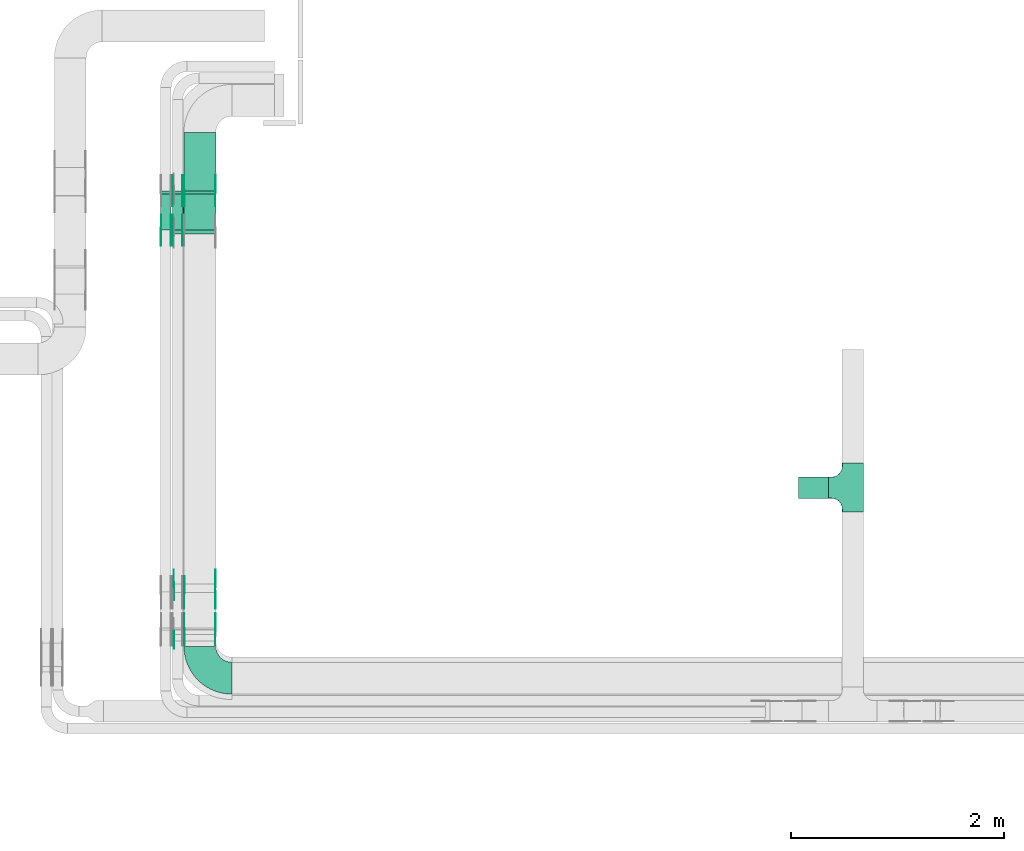
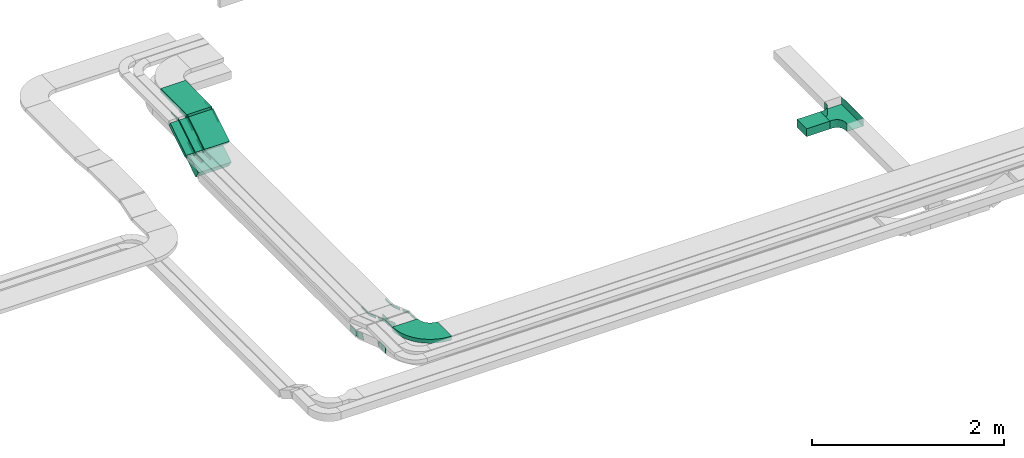
# One storey, part 8 of 28: 31 flow fittings, 6 flow segments.
"""IFC2X3 building model written with IfcOpenShell, lengths in millimetres."""

from ifc_helpers import new_model, entity, si_unit, converted_unit, derived_unit, direction, frame, frame_2d, origin, origin_2d_with_axis, place, context, subcontext, project, spatial, polyline, circle_curve, parameter, trimmed, segment, composite_curve, rectangle, outline, extrude, faceted_brep, source, transform, mapped, material, type_object, type_shapes, element, save


model = new_model("IFC2X3")

# Units and contexts
model_context = context("Model", 3, precision=0.01, world=origin(), true_north=direction((6.12303176911189e-17, 1.0)))
body_context = subcontext(model_context, "Body", "Model", "MODEL_VIEW")
ifc_project = project(units=[si_unit("LENGTHUNIT", "METRE", prefix="MILLI"), si_unit("AREAUNIT", "SQUARE_METRE"), si_unit("VOLUMEUNIT", "CUBIC_METRE"), converted_unit("PLANEANGLEUNIT", "DEGREE", entity("IfcRatioMeasure", 0.0174532925199433), si_unit("PLANEANGLEUNIT", "RADIAN"), dimensions=[0, 0, 0, 0, 0, 0, 0]), si_unit("MASSUNIT", "GRAM", prefix="KILO"), derived_unit("MASSDENSITYUNIT", [(si_unit("MASSUNIT", "GRAM", prefix="KILO"), 1), (si_unit("LENGTHUNIT", "METRE"), -3)]), derived_unit("MOMENTOFINERTIAUNIT", [(si_unit("LENGTHUNIT", "METRE"), 4)]), si_unit("TIMEUNIT", "SECOND"), si_unit("FREQUENCYUNIT", "HERTZ"), si_unit("THERMODYNAMICTEMPERATUREUNIT", "DEGREE_CELSIUS"), derived_unit("THERMALTRANSMITTANCEUNIT", [(si_unit("MASSUNIT", "GRAM", prefix="KILO"), 1), (si_unit("THERMODYNAMICTEMPERATUREUNIT", "KELVIN"), -1), (si_unit("TIMEUNIT", "SECOND"), -3)]), derived_unit("VOLUMETRICFLOWRATEUNIT", [(si_unit("LENGTHUNIT", "METRE"), 3), (si_unit("TIMEUNIT", "SECOND"), -1)]), derived_unit("MASSFLOWRATEUNIT", [(si_unit("MASSUNIT", "GRAM", prefix="KILO"), 1), (si_unit("TIMEUNIT", "SECOND"), -1)]), derived_unit("ROTATIONALFREQUENCYUNIT", [(si_unit("TIMEUNIT", "SECOND"), -1)]), si_unit("ELECTRICCURRENTUNIT", "AMPERE"), si_unit("ELECTRICVOLTAGEUNIT", "VOLT"), si_unit("POWERUNIT", "WATT"), si_unit("FORCEUNIT", "NEWTON", prefix="KILO"), si_unit("ILLUMINANCEUNIT", "LUX"), si_unit("LUMINOUSFLUXUNIT", "LUMEN"), si_unit("LUMINOUSINTENSITYUNIT", "CANDELA"), derived_unit("USERDEFINED", [(si_unit("MASSUNIT", "GRAM", prefix="KILO"), -1), (si_unit("LENGTHUNIT", "METRE"), -2), (si_unit("TIMEUNIT", "SECOND"), 3), (si_unit("LUMINOUSFLUXUNIT", "LUMEN"), 1)]), derived_unit("LINEARVELOCITYUNIT", [(si_unit("LENGTHUNIT", "METRE"), 1), (si_unit("TIMEUNIT", "SECOND"), -1)]), si_unit("PRESSUREUNIT", "PASCAL"), derived_unit("USERDEFINED", [(si_unit("LENGTHUNIT", "METRE"), -2), (si_unit("MASSUNIT", "GRAM", prefix="KILO"), 1), (si_unit("TIMEUNIT", "SECOND"), -2)]), derived_unit("LINEARFORCEUNIT", [(si_unit("MASSUNIT", "GRAM", prefix="KILO"), 1), (si_unit("LENGTHUNIT", "METRE"), 1), (si_unit("TIMEUNIT", "SECOND"), -2), (si_unit("LENGTHUNIT", "METRE"), -1)]), derived_unit("PLANARFORCEUNIT", [(si_unit("MASSUNIT", "GRAM", prefix="KILO"), 1), (si_unit("LENGTHUNIT", "METRE"), 1), (si_unit("TIMEUNIT", "SECOND"), -2), (si_unit("LENGTHUNIT", "METRE"), -2)])], contexts=[model_context])

# Site, building, storey
site_placement = place(None, frame((0.0, -0.00077364408347762, 0.0)))
site = spatial("IfcSite", under=ifc_project, at=site_placement, CompositionType="ELEMENT")
building_placement = place(site_placement, origin())
building = spatial("IfcBuilding", under=site, at=building_placement, CompositionType="ELEMENT")
storey_placement = place(building_placement, origin())
storey = spatial("IfcBuildingStorey", under=building, at=storey_placement, CompositionType="ELEMENT", Elevation=0.0)

# Flow segments
cable_carrier_segment_type = type_object("IfcCableCarrierSegmentType", PredefinedType="CABLETRAYSEGMENT")
flow_segment_1_placement = place(storey_placement, frame((21183.5985265898, 10463.3644987587, 2950.0)))
element("IfcFlowSegment", 1, at=flow_segment_1_placement, inside=storey, type_object=cable_carrier_segment_type, context=body_context, shape_type="SweptSolid", body=[
    extrude(rectangle(XDim=280.000000000001, YDim=200.000000000002, at=frame_2d((-2.1600499167107e-12, -1.08713038571295e-12), x_axis=(1.0, 0.0))), frame((140.0, 100.0, 0.0), z_axis=(0.0, 0.0, 1.0), x_axis=(-1.0, 0.0, 0.0)), (0.0, 0.0, 1.0), 100.0),
])
flow_segment_2_placement = place(storey_placement, frame((15399.9969238281, 12989.8314257229, 3238.73532207177)))
element("IfcFlowSegment", 2, at=flow_segment_2_placement, inside=storey, type_object=cable_carrier_segment_type, context=body_context, shape_type="SweptSolid", body=[
    extrude(rectangle(XDim=50.000000000001, YDim=396.526348882561, at=frame_2d((1.4210854715202e-13, 2.27373675443232e-13), x_axis=(0.0, 1.0))), frame((0.0, 181.384689228763, 126.264677928234), z_axis=(1.0, 0.0, 0.0), x_axis=(0.0, 0.848048096156902, 0.529919264232443)), (0.0, 0.0, 1.0), 300.000000000001),
])
flow_segment_3_placement = place(storey_placement, frame((15299.9969238281, 12948.5495776928, 2956.33291726396)))
element("IfcFlowSegment", 3, at=flow_segment_3_placement, inside=storey, type_object=cable_carrier_segment_type, context=body_context, shape_type="SweptSolid", body=[
    extrude(rectangle(XDim=99.9999999999987, YDim=457.672276185984, at=frame_2d((-7.8159700933611e-13, 8.06466005087714e-13), x_axis=(0.0, 1.0))), frame((0.0, 220.560014453207, 163.667082736049), z_axis=(1.0, 0.0, 0.0), x_axis=(0.0, 0.848048096156363, 0.529919264233306)), (0.0, 0.0, 1.0), 400.0),
])
flow_segment_4_placement = place(storey_placement, frame((15289.9969238281, 12989.831425727, 3238.73532207446)))
element("IfcFlowSegment", 4, at=flow_segment_4_placement, inside=storey, type_object=cable_carrier_segment_type, context=body_context, shape_type="SweptSolid", body=[
    extrude(rectangle(XDim=49.9999999999982, YDim=396.526348877707, at=frame_2d((-6.3948846218409e-13, 1.03206332369155e-12), x_axis=(0.0, 1.0))), frame((0.0, 181.384689226734, 126.264677926897), z_axis=(1.0, 0.0, 0.0), x_axis=(0.0, 0.848048096157075, 0.529919264232167)), (0.0, 0.0, 1.0), 99.9999999999967),
])
flow_segment_5_placement = place(storey_placement, frame((15179.9969238281, 12989.8314257272, 3238.73532207448)))
element("IfcFlowSegment", 5, at=flow_segment_5_placement, inside=storey, type_object=cable_carrier_segment_type, context=body_context, shape_type="SweptSolid", body=[
    extrude(rectangle(XDim=49.9999999999994, YDim=396.526348877544, at=frame_2d((1.83320025826106e-12, -1.15107923193136e-12), x_axis=(0.0, 1.0))), frame((0.0, 181.384689226643, 126.264677926886), z_axis=(1.0, 0.0, 0.0), x_axis=(0.0, 0.848048096156966, 0.529919264232341)), (0.0, 0.0, 1.0), 99.9999999999989),
])
flow_segment_6_placement = place(storey_placement, frame((15399.9969238281, 13356.5685293336, 3450.0)))
element("IfcFlowSegment", 6, at=flow_segment_6_placement, inside=storey, type_object=cable_carrier_segment_type, context=body_context, shape_type="SweptSolid", body=[
    extrude(rectangle(XDim=549.993317234229, YDim=300.000000000001, at=origin_2d_with_axis()), frame((150.0, 274.996658617117, 0.0), z_axis=(0.0, 0.0, 1.0), x_axis=(0.0, 1.0, 0.0)), (0.0, 0.0, 1.0), 49.9999999999995),
])

# Flow fittings
ifc_material_1 = material(Name="G")
cable_carrier_fitting_type_1 = type_object("IfcCableCarrierFittingType", PredefinedType="NOTDEFINED", material=ifc_material_1)
shared_shape_1 = source(origin(), body_context, "Body", "SweptSolid", [
    extrude(outline(composite_curve([segment(trimmed(circle_curve(frame_2d((-44.5901162790698, 0.0), x_axis=(1.0, 0.0)), 12.5), [parameter(90.0000000000007)], [parameter(270.0)], True, "PARAMETER"), True, "CONTINUOUS"), segment(polyline([(-44.5901162790697, -12.5), (-33.0901162790698, -12.5)]), True, "CONTINUOUS"), segment(polyline([(-33.0901162790698, -12.5), (-31.2296511627907, -14.5)]), True, "CONTINUOUS"), segment(polyline([(-31.2296511627907, -14.5), (108.90988372093, -14.5)]), True, "CONTINUOUS"), segment(polyline([(108.90988372093, -14.5), (108.90988372093, 14.5)]), True, "CONTINUOUS"), segment(polyline([(108.90988372093, 14.5), (-31.2296511627907, 14.5)]), True, "CONTINUOUS"), segment(polyline([(-31.2296511627907, 14.5), (-33.0901162790698, 12.5)]), True, "CONTINUOUS"), segment(polyline([(-33.0901162790698, 12.5), (-44.5901162790699, 12.5)]), True, "CONTINUOUS")], self_intersect=False)), frame((44.5901162790698, 0.0, 0.0), z_axis=(0.0, 0.0, -1.0), x_axis=(1.0, 0.0, 0.0)), (0.0, 0.0, -1.0), 2.0),
])
type_shapes(cable_carrier_fitting_type_1, [shared_shape_1])
for number, where, z_axis, x_axis in (
    (7, (15404.536923818, 13347.2529131465, 3475.0), (-1.0, 0.0, 0.0), (0.0, 1.0, 0.0)),
    (8, (15294.536923818, 12995.1793167609, 3255.0), (-1.0, 0.0, 0.0), (0.0, -1.0, 0.0)),
    (9, (15184.536923818, 12995.1793167611, 3255.0), (-1.0, 0.0, 0.0), (0.0, -1.0, 0.0)),
    (10, (15294.536923818, 13347.2529131466, 3475.0), (-1.0, 0.0, 0.0), (0.0, 1.0, 0.0)),
    (11, (15404.536923818, 9230.00006103519, 3375.0), (-1.0, 0.0, 0.0), (0.0, 0.944549723773494, -0.328368420100679)),
    (12, (15404.536923818, 9575.17931674882, 3255.0), (-1.0, 0.0, 0.0), (0.0, -0.944549723773494, 0.328368420100679)),
):
    element("IfcFlowFitting", number, at=place(storey_placement, frame(where, z_axis=z_axis, x_axis=x_axis)), inside=storey, type_object=cable_carrier_fitting_type_1, material=ifc_material_1, context=body_context, shape_type="MappedRepresentation", body=[
        mapped(shared_shape_1, transform((0.0, 0.0, 0.0), scale=1.0)),
    ])
cable_carrier_fitting_type_2 = type_object("IfcCableCarrierFittingType", PredefinedType="NOTDEFINED", material=ifc_material_1)
shared_shape_2 = source(origin(), body_context, "Body", "SweptSolid", [
    extrude(outline(composite_curve([segment(trimmed(circle_curve(frame_2d((-44.5901162790697, 0.0), x_axis=(1.0, 0.0)), 12.5), [parameter(90.0000000000007)], [parameter(270.0)], True, "PARAMETER"), True, "CONTINUOUS"), segment(polyline([(-44.5901162790697, -12.5), (-33.0901162790697, -12.5)]), True, "CONTINUOUS"), segment(polyline([(-33.0901162790697, -12.5), (-31.2296511627907, -14.5)]), True, "CONTINUOUS"), segment(polyline([(-31.2296511627907, -14.5), (108.90988372093, -14.5)]), True, "CONTINUOUS"), segment(polyline([(108.90988372093, -14.5), (108.90988372093, 14.5)]), True, "CONTINUOUS"), segment(polyline([(108.90988372093, 14.5), (-31.2296511627907, 14.5)]), True, "CONTINUOUS"), segment(polyline([(-31.2296511627907, 14.5), (-33.0901162790698, 12.5)]), True, "CONTINUOUS"), segment(polyline([(-33.0901162790698, 12.5), (-44.5901162790699, 12.5)]), True, "CONTINUOUS")], self_intersect=False)), frame((44.5901162790697, 0.0, 0.0)), (0.0, 0.0, 1.0), 2.0),
])
type_shapes(cable_carrier_fitting_type_2, [shared_shape_2])
for number, where, z_axis, x_axis in (
    (13, (15695.4569238383, 13347.2529131465, 3475.0), (1.0, 0.0, 0.0), (0.0, 1.0, 0.0)),
    (14, (15385.4569238383, 12995.1793167609, 3255.0), (1.0, 0.0, 0.0), (0.0, -1.0, 0.0)),
    (15, (15275.4569238383, 12995.1793167611, 3255.0), (1.0, 0.0, 0.0), (0.0, -1.0, 0.0)),
    (16, (15385.4569238383, 13347.2529131466, 3475.0), (1.0, 0.0, 0.0), (0.0, 1.0, 0.0)),
    (17, (15695.4569238383, 9230.00006103519, 3375.0), (1.0, 0.0, 0.0), (0.0, 0.944549723773494, -0.328368420100679)),
    (18, (15695.4569238383, 9575.17931674882, 3255.0), (1.0, 0.0, 0.0), (0.0, -0.944549723773494, 0.328368420100679)),
):
    element("IfcFlowFitting", number, at=place(storey_placement, frame(where, z_axis=z_axis, x_axis=x_axis)), inside=storey, type_object=cable_carrier_fitting_type_2, material=ifc_material_1, context=body_context, shape_type="MappedRepresentation", body=[
        mapped(shared_shape_2, transform((0.0, 0.0, 0.0), scale=1.0)),
    ])
cable_carrier_fitting_type_3 = type_object("IfcCableCarrierFittingType", PredefinedType="NOTDEFINED", material=ifc_material_1)
shared_shape_3 = source(origin(), body_context, "Body", "SweptSolid", [
    extrude(outline(composite_curve([segment(trimmed(circle_curve(frame_2d((-44.5901162790698, 0.0), x_axis=(1.0, 0.0)), 12.5), [parameter(90.0000000000007)], [parameter(270.0)], True, "PARAMETER"), True, "CONTINUOUS"), segment(polyline([(-44.5901162790697, -12.5), (-33.0901162790698, -12.5)]), True, "CONTINUOUS"), segment(polyline([(-33.0901162790698, -12.5), (-31.2296511627907, -14.5)]), True, "CONTINUOUS"), segment(polyline([(-31.2296511627907, -14.5), (108.90988372093, -14.5)]), True, "CONTINUOUS"), segment(polyline([(108.90988372093, -14.5), (108.90988372093, 14.5)]), True, "CONTINUOUS"), segment(polyline([(108.90988372093, 14.5), (-31.2296511627907, 14.5)]), True, "CONTINUOUS"), segment(polyline([(-31.2296511627907, 14.5), (-33.0901162790698, 12.5)]), True, "CONTINUOUS"), segment(polyline([(-33.0901162790698, 12.5), (-44.5901162790699, 12.5)]), True, "CONTINUOUS")], self_intersect=False)), frame((44.5901162790698, 0.0, 0.0), z_axis=(0.0, 0.0, -1.0), x_axis=(1.0, 0.0, 0.0)), (0.0, 0.0, -1.0), 2.0),
])
type_shapes(cable_carrier_fitting_type_3, [shared_shape_3])
for number, where, z_axis, x_axis in (
    (19, (15693.4569238383, 13347.2529131465, 3475.0), (1.0, 0.0, 0.0), (0.0, -0.848048096156421, -0.529919264233212)),
    (20, (15383.4569238383, 12995.1793167609, 3255.0), (1.0, 0.0, 0.0), (0.0, 0.848048096157054, 0.529919264232201)),
    (21, (15273.4569238383, 12995.1793167611, 3255.0), (1.0, 0.0, 0.0), (0.0, 0.848048096156942, 0.529919264232379)),
    (22, (15383.4569238383, 13347.2529131466, 3475.0), (1.0, 0.0, 0.0), (0.0, -0.848048096157089, -0.529919264232144)),
    (23, (15693.4569238383, 9230.0000610352, 3375.0), (1.0, 0.0, 0.0), (0.0, -1.0, 0.0)),
    (24, (15693.4569238383, 9575.1793167488, 3255.0), (1.0, 0.0, 0.0), (0.0, 1.0, 0.0)),
):
    element("IfcFlowFitting", number, at=place(storey_placement, frame(where, z_axis=z_axis, x_axis=x_axis)), inside=storey, type_object=cable_carrier_fitting_type_3, material=ifc_material_1, context=body_context, shape_type="MappedRepresentation", body=[
        mapped(shared_shape_3, transform((0.0, 0.0, 0.0), scale=1.0)),
    ])
cable_carrier_fitting_type_4 = type_object("IfcCableCarrierFittingType", PredefinedType="NOTDEFINED", material=ifc_material_1)
shared_shape_4 = source(origin(), body_context, "Body", "SweptSolid", [
    extrude(outline(composite_curve([segment(trimmed(circle_curve(frame_2d((-44.5901162790697, 0.0), x_axis=(1.0, 0.0)), 12.5), [parameter(90.0000000000007)], [parameter(270.0)], True, "PARAMETER"), True, "CONTINUOUS"), segment(polyline([(-44.5901162790697, -12.5), (-33.0901162790697, -12.5)]), True, "CONTINUOUS"), segment(polyline([(-33.0901162790697, -12.5), (-31.2296511627907, -14.5)]), True, "CONTINUOUS"), segment(polyline([(-31.2296511627907, -14.5), (108.90988372093, -14.5)]), True, "CONTINUOUS"), segment(polyline([(108.90988372093, -14.5), (108.90988372093, 14.5)]), True, "CONTINUOUS"), segment(polyline([(108.90988372093, 14.5), (-31.2296511627907, 14.5)]), True, "CONTINUOUS"), segment(polyline([(-31.2296511627907, 14.5), (-33.0901162790698, 12.5)]), True, "CONTINUOUS"), segment(polyline([(-33.0901162790698, 12.5), (-44.5901162790699, 12.5)]), True, "CONTINUOUS")], self_intersect=False)), frame((44.5901162790697, 0.0, 0.0)), (0.0, 0.0, 1.0), 2.0),
])
type_shapes(cable_carrier_fitting_type_4, [shared_shape_4])
for number, where, z_axis, x_axis in (
    (25, (15406.536923818, 13347.2529131465, 3475.0), (-1.0, 0.0, 0.0), (0.0, -0.848048096156421, -0.529919264233212)),
    (26, (15296.536923818, 12995.1793167609, 3255.0), (-1.0, 0.0, 0.0), (0.0, 0.848048096157054, 0.529919264232201)),
    (27, (15186.536923818, 12995.1793167611, 3255.0), (-1.0, 0.0, 0.0), (0.0, 0.848048096156942, 0.529919264232379)),
    (28, (15296.536923818, 13347.2529131466, 3475.0), (-1.0, 0.0, 0.0), (0.0, -0.848048096157089, -0.529919264232144)),
    (29, (15406.536923818, 9230.0000610352, 3375.0), (-1.0, 0.0, 0.0), (0.0, -1.0, 0.0)),
    (30, (15406.536923818, 9575.1793167488, 3255.0), (-1.0, 0.0, 0.0), (0.0, 1.0, 0.0)),
):
    element("IfcFlowFitting", number, at=place(storey_placement, frame(where, z_axis=z_axis, x_axis=x_axis)), inside=storey, type_object=cable_carrier_fitting_type_4, material=ifc_material_1, context=body_context, shape_type="MappedRepresentation", body=[
        mapped(shared_shape_4, transform((0.0, 0.0, 0.0), scale=1.0)),
    ])
cable_carrier_fitting_type_5 = type_object("IfcCableCarrierFittingType", PredefinedType="NOTDEFINED", material=ifc_material_1)
shared_shape_5 = source(origin(), body_context, "Body", "SweptSolid", [
    extrude(outline(composite_curve([segment(trimmed(circle_curve(frame_2d((-41.4651162790697, 0.0), x_axis=(1.0, 0.0)), 25.0), [parameter(90.0000000000007)], [parameter(270.0)], True, "PARAMETER"), True, "CONTINUOUS"), segment(polyline([(-41.4651162790697, -25.0), (-29.9651162790697, -25.0)]), True, "CONTINUOUS"), segment(polyline([(-29.9651162790697, -25.0), (-28.1046511627907, -38.5)]), True, "CONTINUOUS"), segment(polyline([(-28.1046511627907, -38.5), (99.5348837209303, -38.5)]), True, "CONTINUOUS"), segment(polyline([(99.5348837209303, -38.5), (99.5348837209303, 38.5)]), True, "CONTINUOUS"), segment(polyline([(99.5348837209303, 38.5), (-28.1046511627907, 38.5)]), True, "CONTINUOUS"), segment(polyline([(-28.1046511627907, 38.5), (-29.9651162790697, 25.0)]), True, "CONTINUOUS"), segment(polyline([(-29.9651162790697, 25.0), (-41.46511627907, 25.0)]), True, "CONTINUOUS")], self_intersect=False)), frame((41.4651162790697, 0.0, 0.0), z_axis=(0.0, 0.0, -1.0), x_axis=(1.0, 0.0, 0.0)), (0.0, 0.0, -1.0), 2.0),
])
type_shapes(cable_carrier_fitting_type_5, [shared_shape_5])
flow_fitting_1_placement = place(storey_placement, frame((15695.4569238383, 9650.2390686638, 2990.0), z_axis=(1.0, 0.0, 0.0), x_axis=(0.0, 1.0, 0.0)))
element("IfcFlowFitting", 31, at=flow_fitting_1_placement, inside=storey, type_object=cable_carrier_fitting_type_5, material=ifc_material_1, context=body_context, shape_type="MappedRepresentation", body=[
    mapped(shared_shape_5, transform((0.0, 0.0, 0.0), scale=1.0)),
])
cable_carrier_fitting_type_6 = type_object("IfcCableCarrierFittingType", PredefinedType="NOTDEFINED", material=ifc_material_1)
shared_shape_6 = source(origin(), body_context, "Body", "SweptSolid", [
    extrude(outline(composite_curve([segment(trimmed(circle_curve(frame_2d((-41.4651162790697, 0.0), x_axis=(1.0, 0.0)), 25.0), [parameter(90.0000000000007)], [parameter(270.0)], True, "PARAMETER"), True, "CONTINUOUS"), segment(polyline([(-41.4651162790697, -25.0), (-29.9651162790697, -25.0)]), True, "CONTINUOUS"), segment(polyline([(-29.9651162790697, -25.0), (-28.1046511627907, -38.5)]), True, "CONTINUOUS"), segment(polyline([(-28.1046511627907, -38.5), (99.5348837209303, -38.5)]), True, "CONTINUOUS"), segment(polyline([(99.5348837209303, -38.5), (99.5348837209303, 38.5)]), True, "CONTINUOUS"), segment(polyline([(99.5348837209303, 38.5), (-28.1046511627907, 38.5)]), True, "CONTINUOUS"), segment(polyline([(-28.1046511627907, 38.5), (-29.9651162790697, 25.0)]), True, "CONTINUOUS"), segment(polyline([(-29.9651162790697, 25.0), (-41.46511627907, 25.0)]), True, "CONTINUOUS")], self_intersect=False)), frame((41.4651162790697, 0.0, 0.0)), (0.0, 0.0, 1.0), 2.0),
])
type_shapes(cable_carrier_fitting_type_6, [shared_shape_6])
flow_fitting_2_placement = place(storey_placement, frame((15304.536923818, 9650.2390686638, 2990.0), z_axis=(-1.0, 0.0, 0.0), x_axis=(0.0, 1.0, 0.0)))
element("IfcFlowFitting", 32, at=flow_fitting_2_placement, inside=storey, type_object=cable_carrier_fitting_type_6, material=ifc_material_1, context=body_context, shape_type="MappedRepresentation", body=[
    mapped(shared_shape_6, transform((0.0, 0.0, 0.0), scale=1.0)),
])
cable_carrier_fitting_type_7 = type_object("IfcCableCarrierFittingType", PredefinedType="NOTDEFINED", material=ifc_material_1)
shared_shape_7 = source(origin(), body_context, "Body", "SweptSolid", [
    extrude(outline(composite_curve([segment(trimmed(circle_curve(frame_2d((-41.4651162790697, 0.0), x_axis=(1.0, 0.0)), 25.0), [parameter(90.0000000000007)], [parameter(270.0)], True, "PARAMETER"), True, "CONTINUOUS"), segment(polyline([(-41.4651162790697, -25.0), (-29.9651162790697, -25.0)]), True, "CONTINUOUS"), segment(polyline([(-29.9651162790697, -25.0), (-28.1046511627907, -38.5)]), True, "CONTINUOUS"), segment(polyline([(-28.1046511627907, -38.5), (99.5348837209303, -38.5)]), True, "CONTINUOUS"), segment(polyline([(99.5348837209303, -38.5), (99.5348837209303, 38.5)]), True, "CONTINUOUS"), segment(polyline([(99.5348837209303, 38.5), (-28.1046511627907, 38.5)]), True, "CONTINUOUS"), segment(polyline([(-28.1046511627907, 38.5), (-29.9651162790697, 25.0)]), True, "CONTINUOUS"), segment(polyline([(-29.9651162790697, 25.0), (-41.46511627907, 25.0)]), True, "CONTINUOUS")], self_intersect=False)), frame((41.4651162790697, 0.0, 0.0), z_axis=(0.0, 0.0, -1.0), x_axis=(1.0, 0.0, 0.0)), (0.0, 0.0, -1.0), 2.0),
])
type_shapes(cable_carrier_fitting_type_7, [shared_shape_7])
flow_fitting_3_placement = place(storey_placement, frame((15306.536923818, 9650.23906866381, 2990.0), z_axis=(-1.0, 0.0, 0.0), x_axis=(0.0, -0.94454972377344, 0.328368420100834)))
element("IfcFlowFitting", 33, at=flow_fitting_3_placement, inside=storey, type_object=cable_carrier_fitting_type_7, material=ifc_material_1, context=body_context, shape_type="MappedRepresentation", body=[
    mapped(shared_shape_7, transform((0.0, 0.0, 0.0), scale=1.0)),
])
cable_carrier_fitting_type_8 = type_object("IfcCableCarrierFittingType", PredefinedType="NOTDEFINED", material=ifc_material_1)
shared_shape_8 = source(origin(), body_context, "Body", "SweptSolid", [
    extrude(outline(composite_curve([segment(trimmed(circle_curve(frame_2d((-41.4651162790697, 0.0), x_axis=(1.0, 0.0)), 25.0), [parameter(90.0000000000007)], [parameter(270.0)], True, "PARAMETER"), True, "CONTINUOUS"), segment(polyline([(-41.4651162790697, -25.0), (-29.9651162790697, -25.0)]), True, "CONTINUOUS"), segment(polyline([(-29.9651162790697, -25.0), (-28.1046511627907, -38.5)]), True, "CONTINUOUS"), segment(polyline([(-28.1046511627907, -38.5), (99.5348837209303, -38.5)]), True, "CONTINUOUS"), segment(polyline([(99.5348837209303, -38.5), (99.5348837209303, 38.5)]), True, "CONTINUOUS"), segment(polyline([(99.5348837209303, 38.5), (-28.1046511627907, 38.5)]), True, "CONTINUOUS"), segment(polyline([(-28.1046511627907, 38.5), (-29.9651162790697, 25.0)]), True, "CONTINUOUS"), segment(polyline([(-29.9651162790697, 25.0), (-41.46511627907, 25.0)]), True, "CONTINUOUS")], self_intersect=False)), frame((41.4651162790697, 0.0, 0.0)), (0.0, 0.0, 1.0), 2.0),
])
type_shapes(cable_carrier_fitting_type_8, [shared_shape_8])
for number, where, z_axis, x_axis in (
    (34, (15306.536923818, 9190.00006103524, 3150.0), (-1.0, 0.0, 0.0), (0.0, -1.0, 0.0)),
    (35, (15693.4569238383, 9650.23906866381, 2990.0), (1.0, 0.0, 0.0), (0.0, -0.94454972377344, 0.328368420100834)),
):
    element("IfcFlowFitting", number, at=place(storey_placement, frame(where, z_axis=z_axis, x_axis=x_axis)), inside=storey, type_object=cable_carrier_fitting_type_8, material=ifc_material_1, context=body_context, shape_type="MappedRepresentation", body=[
        mapped(shared_shape_8, transform((0.0, 0.0, 0.0), scale=1.0)),
    ])
ifc_material_2 = material()
cable_carrier_fitting_type_9 = type_object("IfcCableCarrierFittingType", PredefinedType="NOTDEFINED", material=ifc_material_2)
shared_shape_9 = source(origin(), body_context, "Body", "Brep", [
    faceted_brep([(-103.407417371087, -174.118095489753, 50.0), (-100.0, -200.0, 50.0), (-100.0, -230.0, 50.0), (-99.1999999999932, -230.0, 50.0), (-99.1999999999933, -200.0, 50.0), (-102.634676710055, -173.911040253671, 50.0), (-112.704639298522, -149.600000000004, 50.0), (-128.723636456391, -128.7236364564, 50.0), (-149.599999999996, -112.704639298532, 50.0), (-173.911040253663, -102.634676710066, 50.0), (-200.0, -99.2000000000044, 50.0), (-230.0, -99.2000000000044, 50.0), (-230.0, -100.0, 50.0), (-200.0, -100.0, 50.0), (-174.118095489746, -103.407417371099, 50.0), (-150.0, -113.397459621561, 50.0), (-129.28932188134, -129.28932188135, 50.0), (-113.39745962155, -150.0, 50.0), (230.0, -100.0, 50.0), (230.0, -99.2000000000044, 50.0), (200.0, -99.2000000000097, 50.0), (173.911040253722, -102.634676710071, 50.0), (149.60000000005, -112.704639298537, 50.0), (128.723636456439, -128.723636456403, 50.0), (112.704639298563, -149.600000000006, 50.0), (102.634676710086, -173.911040253673, 50.0), (99.2000000000121, -200.0, 50.0), (99.2000000000069, -230.0, 50.0), (100.0, -230.0, 50.0), (100.0, -200.0, 50.0), (103.407417371119, -174.118095489755, 50.0), (113.397459621593, -150.0, 50.0), (129.289321881391, -129.289321881354, 50.0), (150.0, -113.397459621567, 50.0), (174.118095489805, -103.407417371105, 50.0), (200.0, -100.0, 50.0), (230.0, 99.1999999999954, 50.0), (230.0, 100.0, 50.0), (-230.0, 100.0, 50.0), (-230.0, 99.1999999999954, 50.0), (-230.0, -100.0, -50.0), (-230.0, 100.0, -50.0), (230.0, 100.0, -50.0), (230.0, -100.0, -50.0), (200.0, -100.0, -50.0), (174.118095489805, -103.407417371105, -50.0), (150.0, -113.397459621567, -50.0), (129.289321881391, -129.289321881354, -50.0), (113.397459621593, -150.0, -50.0), (103.407417371119, -174.118095489755, -50.0), (100.0, -200.0, -50.0), (100.0, -230.0, -50.0), (-100.0, -230.0, -50.0), (-100.0, -200.0, -50.0), (-103.407417371087, -174.118095489753, -50.0), (-113.39745962155, -150.0, -50.0), (-129.28932188134, -129.28932188135, -50.0), (-150.0, -113.397459621561, -50.0), (-174.118095489746, -103.407417371099, -50.0), (-200.0, -100.0, -50.0), (-100.0, -200.0, -49.1999999999851), (99.2000000000069, -230.0, -49.1999999999851), (-99.1999999999932, -230.0, -49.1999999999851), (-99.1999999999933, -200.0, -49.1999999999851), (-200.0, -99.2000000000044, -49.1999999999851), (-230.0, -99.2000000000044, -49.1999999999851), (230.0, -99.2000000000044, -49.1999999999851), (200.0, -99.2000000000044, -49.1999999999851), (-230.0, 99.1999999999954, -49.1999999999851), (-200.0, -100.0, -49.1999999999851), (200.0, -100.0, -49.1999999999851), (230.0, 99.1999999999954, -49.1999999999851), (99.2000000000121, -200.0, -49.1999999999851), (100.0, -200.0, -49.1999999999851), (-173.911040253663, -102.634676710066, -49.1999999999851), (-149.599999999996, -112.704639298532, -49.1999999999851), (-128.723636456391, -128.7236364564, -49.1999999999851), (-112.704639298522, -149.600000000004, -49.1999999999851), (-102.634676710055, -173.911040253671, -49.1999999999851), (102.634676710086, -173.911040253674, -49.1999999999851), (112.704639298563, -149.600000000007, -49.1999999999851), (128.723636456439, -128.723636456403, -49.1999999999851), (149.60000000005, -112.704639298537, -49.1999999999851), (173.911040253721, -102.634676710071, -49.1999999999851)], [[[0, 1, 2, 3, 4, 5, 6, 7, 8, 9, 10, 11, 12, 13, 14, 15, 16, 17]], [[18, 19, 20, 21, 22, 23, 24, 25, 26, 27, 28, 29, 30, 31, 32, 33, 34, 35]], [[36, 37, 38, 39]], [[40, 41, 42, 43, 44, 45, 46, 47, 48, 49, 50, 51, 52, 53, 54, 55, 56, 57, 58, 59]], [[2, 1, 60, 53, 52]], [[3, 2, 52, 51, 28, 27, 61, 62]], [[4, 3, 62, 63]], [[11, 10, 64, 65]], [[20, 19, 66, 67]], [[39, 38, 41, 40, 12, 11, 65, 68]], [[13, 12, 40, 59, 69]], [[18, 35, 70, 44, 43]], [[19, 18, 43, 42, 37, 36, 71, 66]], [[27, 26, 72, 61]], [[29, 28, 51, 50, 73]], [[38, 37, 42, 41]], [[36, 39, 68, 71]], [[68, 65, 64, 74, 75, 76, 77, 78, 63, 62, 61, 72, 79, 80, 81, 82, 83, 67, 66, 71]], [[14, 13, 69, 59, 58]], [[15, 14, 58, 57]], [[57, 56, 16, 15]], [[17, 16, 56, 55]], [[0, 17, 55, 54]], [[1, 0, 54, 53, 60]], [[5, 78, 77, 6]], [[6, 77, 76, 7]], [[63, 78, 5, 4]], [[8, 75, 74, 9]], [[9, 74, 64, 10]], [[7, 76, 75, 8]], [[21, 83, 82, 22]], [[22, 82, 81, 23]], [[67, 83, 21, 20]], [[24, 80, 79, 25]], [[25, 79, 72, 26]], [[23, 81, 80, 24]], [[30, 29, 73, 50, 49]], [[31, 30, 49, 48]], [[32, 31, 48, 47]], [[34, 33, 46, 45]], [[34, 45, 44, 70, 35]], [[46, 33, 32, 47]]]),
])
type_shapes(cable_carrier_fitting_type_9, [shared_shape_9])
flow_fitting_4_placement = place(storey_placement, frame((21693.5985265899, 10563.3644987587, 3000.0), z_axis=(0.0, 0.0, 1.0), x_axis=(0.0, -1.0, 0.0)))
element("IfcFlowFitting", 36, at=flow_fitting_4_placement, inside=storey, type_object=cable_carrier_fitting_type_9, material=ifc_material_2, Name="470_DKC_S5_T", context=body_context, shape_type="MappedRepresentation", body=[
    mapped(shared_shape_9, transform((0.0, 0.0, 0.0), scale=1.0)),
])
cable_carrier_fitting_type_10 = type_object("IfcCableCarrierFittingType", Name="470_DKC_S5_Variable Angle Elbow 0-45:-", PredefinedType="NOTDEFINED", material=ifc_material_2)
shared_shape_10 = source(origin(), body_context, "Body", "SweptSolid", [
    extrude(outline(composite_curve([segment(polyline([(-150.749999999996, -300.250000000003), (-149.749999999994, -300.250000000003)]), True, "CONTINUOUS"), segment(trimmed(circle_curve(frame_2d((-149.750000000002, 149.749999999997), x_axis=(0.0, -1.0)), 450.0), [parameter(0.0)], [parameter(90.0000000000001)], True, "PARAMETER"), True, "CONTINUOUS"), segment(polyline([(300.249999999997, 149.750000000005), (300.249999999997, 150.750000000004)]), True, "CONTINUOUS"), segment(polyline([(300.249999999997, 150.750000000003), (0.249999999997449, 150.750000000002)]), True, "CONTINUOUS"), segment(polyline([(0.249999999997449, 150.750000000002), (0.249999999997438, 149.75)]), True, "CONTINUOUS"), segment(trimmed(circle_curve(frame_2d((-149.750000000002, 149.749999999997), x_axis=(0.0, -1.0)), 150.0), [parameter(0.0)], [parameter(90.0000000000001)], True, "PARAMETER"), False, "CONTINUOUS"), segment(polyline([(-149.749999999999, -0.250000000002818), (-150.750000000001, -0.250000000002835)]), True, "CONTINUOUS"), segment(polyline([(-150.750000000001, -0.250000000002835), (-150.749999999996, -300.250000000003)]), True, "CONTINUOUS")], self_intersect=False)), frame((-150.249999999991, 150.249999999992, -25.0)), (0.0, 0.0, 1.0), 49.9999999999974),
])
type_shapes(cable_carrier_fitting_type_10, [shared_shape_10])
flow_fitting_5_placement = place(storey_placement, frame((15549.9969238281, 8770.00006103514, 3375.0), z_axis=(0.0, 0.0, 1.0), x_axis=(0.0, -1.0, 0.0)))
element("IfcFlowFitting", 37, at=flow_fitting_5_placement, inside=storey, type_object=cable_carrier_fitting_type_10, material=ifc_material_2, Name="470_DKC_S5_Variable Angle Elbow 0-45:-", ObjectType="470_DKC_S5_Variable Angle Elbow 0-45:-", context=body_context, shape_type="MappedRepresentation", body=[
    mapped(shared_shape_10, transform((0.0, 0.0, 0.0), scale=1.0)),
])

save(model, "model.ifc")
